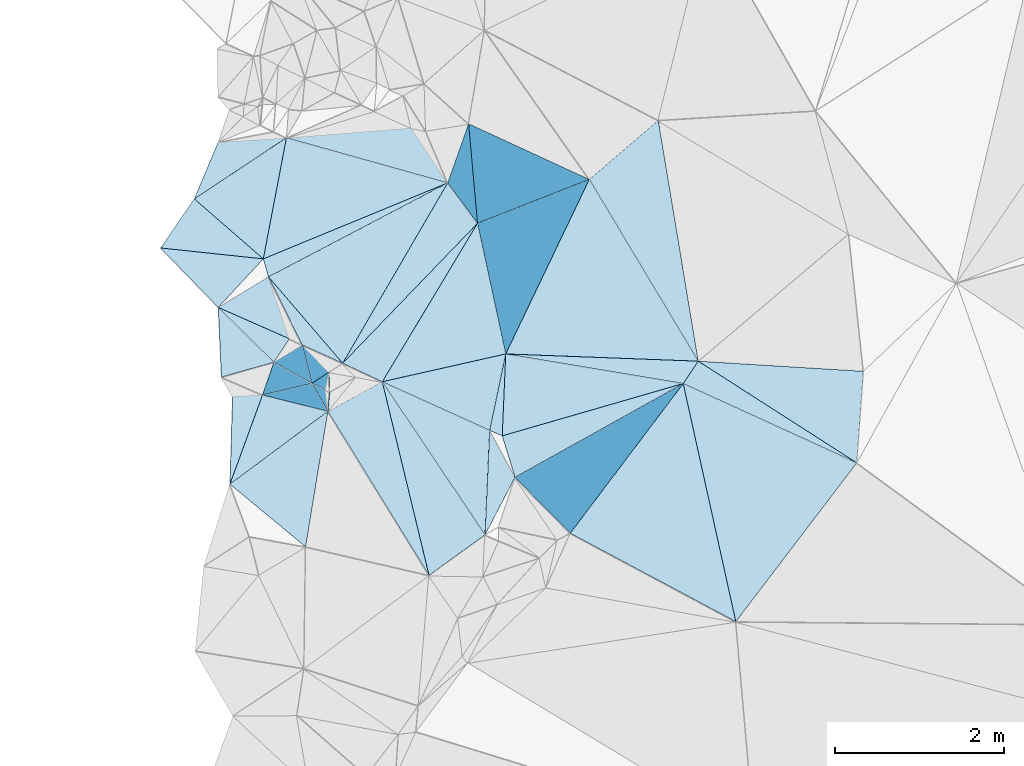
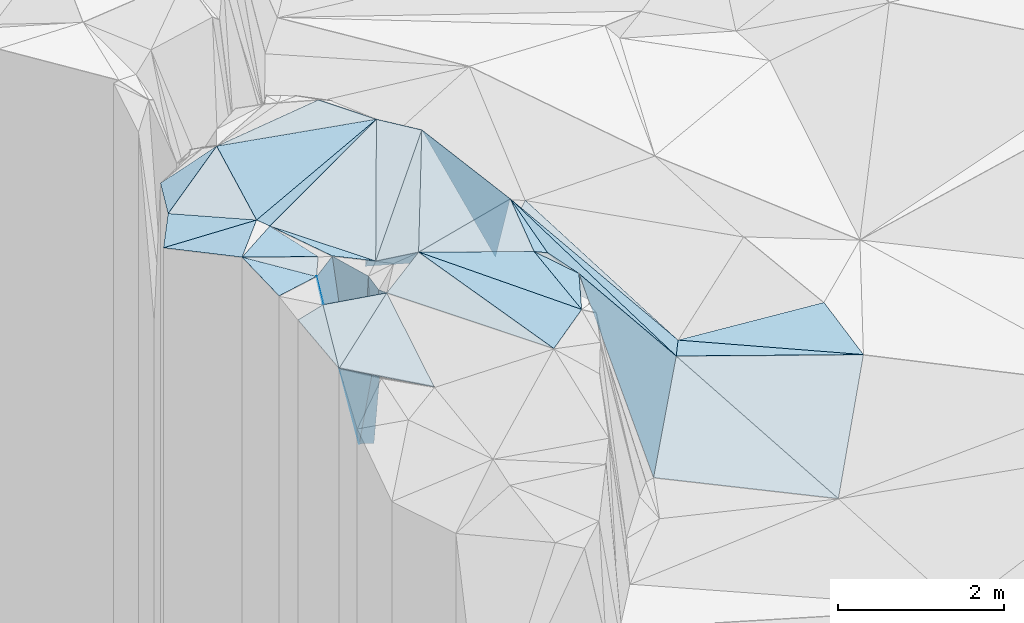
# One storey, part 72 of 275: 45 plates.
"""IFC2X3 building model written with IfcOpenShell, lengths in millimetres."""

from ifc_helpers import new_model, si_unit, frame, origin_with_axes, place, context, subcontext, project, spatial, polyline, outline, extrude, material, type_object, element, save


model = new_model("IFC2X3")

# Units and contexts
model_context = context("Model", 3, precision=1e-05, world=origin_with_axes())
body_context = subcontext(model_context, "Body", "Model", "MODEL_VIEW")
ifc_project = project(units=[si_unit("LENGTHUNIT", "METRE", prefix="MILLI"), si_unit("AREAUNIT", "SQUARE_METRE"), si_unit("VOLUMEUNIT", "CUBIC_METRE"), si_unit("MASSUNIT", "GRAM", prefix="KILO"), si_unit("TIMEUNIT", "SECOND"), si_unit("PLANEANGLEUNIT", "RADIAN"), si_unit("SOLIDANGLEUNIT", "STERADIAN"), si_unit("THERMODYNAMICTEMPERATUREUNIT", "DEGREE_CELSIUS"), si_unit("LUMINOUSINTENSITYUNIT", "LUMEN")], contexts=[model_context])

# Site, building, storey
site_placement = place(None, origin_with_axes())
site = spatial("IfcSite", under=ifc_project, at=site_placement, CompositionType="ELEMENT")
building_placement = place(site_placement, origin_with_axes())
building = spatial("IfcBuilding", under=site, at=building_placement, Name="Undefined", CompositionType="ELEMENT")
storey_placement = place(building_placement, origin_with_axes())
storey = spatial("IfcBuildingStorey", under=building, at=storey_placement, Name="Undefined", CompositionType="ELEMENT", Elevation=0.0)

# Plates
ifc_material = material()
plate_type_1 = type_object("IfcPlateType", PredefinedType="NOTDEFINED")
plate_1_placement = place(storey_placement, frame((-133019.214456108, 91804.0141480025, 54299.5073777721), z_axis=(0.0102797063063867, 0.170975746652722, -0.985221610448532), x_axis=(0.161525662162065, -0.972618108698665, -0.167103186967032)))
element("IfcPlate", 1, at=plate_1_placement, inside=storey, type_object=plate_type_1, material=ifc_material, Name="00", context=body_context, shape_type="SweptSolid", body=[
    extrude(outline(polyline([(0.0, 0.0), (2932.31982421875, 6.47560227662325e-09), (570.640319824219, 921.015502929688), (0.0, 0.0)])), frame((-8.85201319254618e-08, 2.18876761149539e-07, -0.5000001331573), z_axis=(0.0, 0.0, 1.0), x_axis=(1.0, 0.0, 0.0)), (0.0, 0.0, 1.0), 1.0),
])
plate_type_2 = type_object("IfcPlateType", PredefinedType="NOTDEFINED")
plate_2_placement = place(storey_placement, frame((-135512.316042454, 91062.5797967738, 56809.5019135538), z_axis=(0.0469086882632694, 0.0744422740113559, -0.99612143978806), x_axis=(-0.922200361025623, -0.379983834294924, -0.0718246461790003)))
element("IfcPlate", 2, at=plate_2_placement, inside=storey, type_object=plate_type_2, material=ifc_material, Name="00", context=body_context, shape_type="SweptSolid", body=[
    extrude(outline(polyline([(0.0, 0.0), (2366.87548828125, 2.14495230466127e-08), (1561.08752441406, 1222.29528808594), (0.0, 0.0)])), frame((-8.85201319254618e-08, 2.18876761149539e-07, -0.5000001331573), z_axis=(0.0, 0.0, 1.0), x_axis=(1.0, 0.0, 0.0)), (0.0, 0.0, 1.0), 1.0),
])
plate_type_3 = type_object("IfcPlateType", PredefinedType="NOTDEFINED")
plate_3_placement = place(storey_placement, frame((-135069.725982728, 86895.7332848351, 56389.5014990428), z_axis=(-0.0406248918595986, 0.066225253315251, -0.996977348782171), x_axis=(-0.555674663331847, 0.827767819080806, 0.0776279989774612)))
element("IfcPlate", 3, at=plate_3_placement, inside=storey, type_object=plate_type_3, material=ifc_material, Name="00", context=body_context, shape_type="SweptSolid", body=[
    extrude(outline(polyline([(0.0, 0.0), (2189.93139648438, 6.11908035352826e-09), (1000.53356933594, 734.801025390625), (0.0, 0.0)])), frame((-8.85201319254618e-08, 2.18876761149539e-07, -0.5000001331573), z_axis=(0.0, 0.0, 1.0), x_axis=(1.0, 0.0, 0.0)), (0.0, 0.0, 1.0), 1.0),
])
plate_type_4 = type_object("IfcPlateType", PredefinedType="NOTDEFINED")
plate_4_placement = place(storey_placement, frame((-138090.200132588, 87495.7062504348, 56219.509534676), z_axis=(0.00755487445740724, 0.194475120494153, -0.980878357076308), x_axis=(0.796288406474138, 0.592167739934259, 0.123540040051918)))
element("IfcPlate", 4, at=plate_4_placement, inside=storey, type_object=plate_type_4, material=ifc_material, Name="00", context=body_context, shape_type="SweptSolid", body=[
    extrude(outline(polyline([(0.0, 0.0), (1457.01745605469, 1.74331944435835e-08), (257.512359619141, 1142.49169921875), (0.0, 0.0)])), frame((-8.85201319254618e-08, 2.18876761149539e-07, -0.5000001331573), z_axis=(0.0, 0.0, 1.0), x_axis=(1.0, 0.0, 0.0)), (0.0, 0.0, 1.0), 1.0),
])
plate_type_5 = type_object("IfcPlateType", PredefinedType="NOTDEFINED")
plate_5_placement = place(storey_placement, frame((-136755.149502886, 88927.6789404516, 56459.5113759469), z_axis=(0.212194338874322, 0.00788030484290911, -0.977195713941313), x_axis=(0.685469337821501, 0.711502170225779, 0.154584762090448)))
element("IfcPlate", 5, at=plate_5_placement, inside=storey, type_object=plate_type_5, material=ifc_material, Name="00", context=body_context, shape_type="SweptSolid", body=[
    extrude(outline(polyline([(0.0, 0.0), (2328.8193359375, 1.71712599694729e-09), (180.7353515625, 495.009826660156), (0.0, 0.0)])), frame((-8.85201319254618e-08, 2.18876761149539e-07, -0.5000001331573), z_axis=(0.0, 0.0, 1.0), x_axis=(1.0, 0.0, 0.0)), (0.0, 0.0, 1.0), 1.0),
])
plate_type_6 = type_object("IfcPlateType", PredefinedType="NOTDEFINED")
plate_6_placement = place(storey_placement, frame((-137704.779445625, 88552.0196967348, 56379.8982663282), z_axis=(-0.901601279238394, 0.381755940301461, -0.20341468806416), x_axis=(0.3131194597647, 0.900418097282821, 0.301999096028856)))
element("IfcPlate", 6, at=plate_6_placement, inside=storey, type_object=plate_type_6, material=ifc_material, Name="00", context=body_context, shape_type="SweptSolid", body=[
    extrude(outline(polyline([(0.0, 0.0), (430.464874267578, -2.73576006293297e-09), (-396.548034667969, 2373.15185546875), (0.0, 0.0)])), frame((-8.85201319254618e-08, 2.18876761149539e-07, -0.5000001331573), z_axis=(0.0, 0.0, 1.0), x_axis=(1.0, 0.0, 0.0)), (0.0, 0.0, 1.0), 1.0),
])
plate_type_7 = type_object("IfcPlateType", PredefinedType="NOTDEFINED")
plate_7_placement = place(storey_placement, frame((-134866.757399001, 88068.1037368284, 56439.6993643037), z_axis=(-0.784587779004324, 0.151405444524645, -0.601247377046551), x_axis=(0.041968492757815, 0.98047070605122, 0.192134953069608)))
element("IfcPlate", 7, at=plate_7_placement, inside=storey, type_object=plate_type_7, material=ifc_material, Name="00", context=body_context, shape_type="SweptSolid", body=[
    extrude(outline(polyline([(0.0, 0.0), (988.888244628906, 4.97675500810146e-09), (189.809112548828, 3450.74951171875), (0.0, 0.0)])), frame((-8.85201319254618e-08, 2.18876761149539e-07, -0.5000001331573), z_axis=(0.0, 0.0, 1.0), x_axis=(1.0, 0.0, 0.0)), (0.0, 0.0, 1.0), 1.0),
])
plate_type_8 = type_object("IfcPlateType", PredefinedType="NOTDEFINED")
plate_8_placement = place(storey_placement, frame((-137695.049149037, 90163.160322179, 56639.5006148275), z_axis=(0.0476237462637835, -0.0155279606071227, -0.998744642654561), x_axis=(-0.993200359379494, 0.105602677850897, -0.0490012301801052)))
element("IfcPlate", 8, at=plate_8_placement, inside=storey, type_object=plate_type_8, material=ifc_material, Name="00", context=body_context, shape_type="SweptSolid", body=[
    extrude(outline(polyline([(0.0, 0.0), (1224.45910644531, -9.31322574615479e-10), (888.88232421875, 619.990539550781), (0.0, 0.0)])), frame((-8.85201319254618e-08, 2.18876761149539e-07, -0.5000001331573), z_axis=(0.0, 0.0, 1.0), x_axis=(1.0, 0.0, 0.0)), (0.0, 0.0, 1.0), 1.0),
])
plate_type_9 = type_object("IfcPlateType", PredefinedType="NOTDEFINED")
plate_9_placement = place(storey_placement, frame((-138090.082118024, 87495.637834506, 56219.5158988246), z_axis=(0.243513532106445, 0.0576990744786412, -0.968179723236007), x_axis=(0.0301483547749208, 0.997296237000708, 0.0670171050448606)))
element("IfcPlate", 9, at=plate_9_placement, inside=storey, type_object=plate_type_9, material=ifc_material, Name="00", context=body_context, shape_type="SweptSolid", body=[
    extrude(outline(polyline([(0.0, 0.0), (1044.50939941406, -3.79804987460375e-09), (1075.72033691406, 364.590026855469), (0.0, 0.0)])), frame((-8.85201319254618e-08, 2.18876761149539e-07, -0.5000001331573), z_axis=(0.0, 0.0, 1.0), x_axis=(1.0, 0.0, 0.0)), (0.0, 0.0, 1.0), 1.0),
])
plate_type_10 = type_object("IfcPlateType", PredefinedType="NOTDEFINED")
plate_10_placement = place(storey_placement, frame((-136755.368464417, 88927.6732586223, 56459.5129054558), z_axis=(-0.225812033892531, -0.00342194722023315, -0.97416488112975), x_axis=(-0.892356136575741, 0.401865812004755, 0.205437081991972)))
element("IfcPlate", 10, at=plate_10_placement, inside=storey, type_object=plate_type_10, material=ifc_material, Name="00", context=body_context, shape_type="SweptSolid", body=[
    extrude(outline(polyline([(0.0, 0.0), (535.443725585938, -4.27826307713985e-09), (1235.61071777344, 573.991516113281), (0.0, 0.0)])), frame((-8.85201319254618e-08, 2.18876761149539e-07, -0.5000001331573), z_axis=(0.0, 0.0, 1.0), x_axis=(1.0, 0.0, 0.0)), (0.0, 0.0, 1.0), 1.0),
])
plate_type_11 = type_object("IfcPlateType", PredefinedType="NOTDEFINED")
plate_11_placement = place(storey_placement, frame((-138228.253617538, 89588.5701485262, 56629.5034068954), z_axis=(-0.0199411727914742, 0.115282046232752, -0.993132619262951), x_axis=(0.853834207138096, 0.518759924394001, 0.0430730491559356)))
element("IfcPlate", 11, at=plate_11_placement, inside=storey, type_object=plate_type_11, material=ifc_material, Name="00", context=body_context, shape_type="SweptSolid", body=[
    extrude(outline(polyline([(0.0, 0.0), (696.4912109375, 4.13274392485619e-09), (523.768249511719, 758.990661621094), (0.0, 0.0)])), frame((-8.85201319254618e-08, 2.18876761149539e-07, -0.5000001331573), z_axis=(0.0, 0.0, 1.0), x_axis=(1.0, 0.0, 0.0)), (0.0, 0.0, 1.0), 1.0),
])
plate_type_12 = type_object("IfcPlateType", PredefinedType="NOTDEFINED")
plate_12_placement = place(storey_placement, frame((-132545.912939233, 88952.1395896651, 53809.7193433031), z_axis=(-0.676516597305727, 0.476739187252369, -0.561288732211712), x_axis=(-0.55825685568079, -0.829076551856979, -0.031326574123883)))
element("IfcPlate", 12, at=plate_12_placement, inside=storey, type_object=plate_type_12, material=ifc_material, Name="00", context=body_context, shape_type="SweptSolid", body=[
    extrude(outline(polyline([(0.0, 0.0), (319.217803955078, 2.61934474110603e-09), (1113.033203125, 3451.96435546875), (0.0, 0.0)])), frame((-8.85201319254618e-08, 2.18876761149539e-07, -0.5000001331573), z_axis=(0.0, 0.0, 1.0), x_axis=(1.0, 0.0, 0.0)), (0.0, 0.0, 1.0), 1.0),
])
plate_type_13 = type_object("IfcPlateType", PredefinedType="NOTDEFINED")
plate_13_placement = place(storey_placement, frame((-134715.401101913, 87577.2415554032, 56379.6779337774), z_axis=(-0.749592922415684, -0.152423767629284, -0.644109808748484), x_axis=(-0.292718936251035, 0.949129923037372, 0.116051771012485)))
element("IfcPlate", 13, at=plate_13_placement, inside=storey, type_object=plate_type_13, material=ifc_material, Name="00", context=body_context, shape_type="SweptSolid", body=[
    extrude(outline(polyline([(0.0, 0.0), (517.010620117188, 7.42147676646709e-10), (171.176361083984, 3438.61865234375), (0.0, 0.0)])), frame((-8.85201319254618e-08, 2.18876761149539e-07, -0.5000001331573), z_axis=(0.0, 0.0, 1.0), x_axis=(1.0, 0.0, 0.0)), (0.0, 0.0, 1.0), 1.0),
])
plate_type_14 = type_object("IfcPlateType", PredefinedType="NOTDEFINED")
plate_14_placement = place(storey_placement, frame((-137120.43305099, 88689.3291927236, 54049.9519806931), z_axis=(-0.400933713068421, -0.91106170820296, -0.0960141738050935), x_axis=(0.916010796100385, -0.397164333799256, -0.0564332648828032)))
element("IfcPlate", 14, at=plate_14_placement, inside=storey, type_object=plate_type_14, material=ifc_material, Name="00", context=body_context, shape_type="SweptSolid", body=[
    extrude(outline(polyline([(0.0, 0.0), (177.200454711914, 2.09547579288483e-09), (173.250122070313, 2374.54931640625), (0.0, 0.0)])), frame((-8.85201319254618e-08, 2.18876761149539e-07, -0.5000001331573), z_axis=(0.0, 0.0, 1.0), x_axis=(1.0, 0.0, 0.0)), (0.0, 0.0, 1.0), 1.0),
])
plate_15_placement = place(storey_placement, frame((-136916.704785946, 88823.8694605502, 56359.956241492), z_axis=(0.391733126977046, 0.915912209491296, -0.0874641740003226), x_axis=(-0.0176079577659123, -0.0875813731552263, -0.996001738401876)))
element("IfcPlate", 15, at=plate_15_placement, inside=storey, type_object=plate_type_14, material=ifc_material, Name="00", context=body_context, shape_type="SweptSolid", body=[
    extrude(outline(polyline([(0.0, 0.0), (2329.31323242188, -5.96628524363041e-09), (2316.04760742188, 176.703201293945), (0.0, 0.0)])), frame((-8.85201319254618e-08, 2.18876761149539e-07, -0.5000001331573), z_axis=(0.0, 0.0, 1.0), x_axis=(1.0, 0.0, 0.0)), (0.0, 0.0, 1.0), 1.0),
])
plate_type_15 = type_object("IfcPlateType", PredefinedType="NOTDEFINED")
plate_16_placement = place(storey_placement, frame((-130668.546409526, 87748.1052065247, 53669.5012166673), z_axis=(-0.0350781551410021, 0.0613103172055421, -0.997502164426754), x_axis=(-0.908035396471917, 0.414937188493061, 0.0574356018473136)))
element("IfcPlate", 16, at=plate_16_placement, inside=storey, type_object=plate_type_15, material=ifc_material, Name="00", context=body_context, shape_type="SweptSolid", body=[
    extrude(outline(polyline([(0.0, 0.0), (2263.40454101563, 8.83301254361868e-09), (2211.9775390625, 315.048034667969), (0.0, 0.0)])), frame((-8.85201319254618e-08, 2.18876761149539e-07, -0.5000001331573), z_axis=(0.0, 0.0, 1.0), x_axis=(1.0, 0.0, 0.0)), (0.0, 0.0, 1.0), 1.0),
])
plate_type_16 = type_object("IfcPlateType", PredefinedType="NOTDEFINED")
plate_17_placement = place(storey_placement, frame((-136755.266391725, 88927.7619792935, 56459.5077355599), z_axis=(-0.0216654402157595, 0.174017716652183, -0.984504160982277), x_axis=(-0.644659688367644, 0.750242950066391, 0.146797145985239)))
element("IfcPlate", 17, at=plate_17_placement, inside=storey, type_object=plate_type_16, material=ifc_material, Name="00", context=body_context, shape_type="SweptSolid", body=[
    extrude(outline(polyline([(0.0, 0.0), (1362.42431640625, -1.91503204405308e-08), (851.790466308594, 2345.09130859375), (0.0, 0.0)])), frame((-8.85201319254618e-08, 2.18876761149539e-07, -0.5000001331573), z_axis=(0.0, 0.0, 1.0), x_axis=(1.0, 0.0, 0.0)), (0.0, 0.0, 1.0), 1.0),
])
plate_type_17 = type_object("IfcPlateType", PredefinedType="NOTDEFINED")
plate_18_placement = place(storey_placement, frame((-137704.29972498, 88551.893222071, 56379.5049994247), z_axis=(0.0577590349431024, 0.128864102756606, -0.989978755783768), x_axis=(0.969885675995921, -0.242268912774627, 0.0250509361289355)))
element("IfcPlate", 18, at=plate_18_placement, inside=storey, type_object=plate_type_17, material=ifc_material, Name="00", context=body_context, shape_type="SweptSolid", body=[
    extrude(outline(polyline([(0.0, 0.0), (798.373352050781, 5.18775777891278e-09), (-122.373825073242, 1129.21411132813), (0.0, 0.0)])), frame((-8.85201319254618e-08, 2.18876761149539e-07, -0.5000001331573), z_axis=(0.0, 0.0, 1.0), x_axis=(1.0, 0.0, 0.0)), (0.0, 0.0, 1.0), 1.0),
])
plate_type_18 = type_object("IfcPlateType", PredefinedType="NOTDEFINED")
plate_19_placement = place(storey_placement, frame((-137233.3052034, 89143.2795383306, 56569.9121385493), z_axis=(-0.486191840763157, 0.856012644357831, -0.175669709041847), x_axis=(0.0440243342604755, -0.17677971304545, -0.98326537163092)))
element("IfcPlate", 19, at=plate_19_placement, inside=storey, type_object=plate_type_18, material=ifc_material, Name="00", context=body_context, shape_type="SweptSolid", body=[
    extrude(outline(polyline([(0.0, 0.0), (2562.88891601563, -1.60071067512035e-10), (80.143928527832, 389.585601806641), (0.0, 0.0)])), frame((-8.85201319254618e-08, 2.18876761149539e-07, -0.5000001331573), z_axis=(0.0, 0.0, 1.0), x_axis=(1.0, 0.0, 0.0)), (0.0, 0.0, 1.0), 1.0),
])
plate_type_19 = type_object("IfcPlateType", PredefinedType="NOTDEFINED")
plate_20_placement = place(storey_placement, frame((-133836.286220271, 91103.7548794404, 54169.7079565292), z_axis=(-0.73552958499505, -0.343315165919083, -0.584064145832427), x_axis=(0.509028183156125, -0.848953245880516, -0.142016530945204)))
element("IfcPlate", 20, at=plate_20_placement, inside=storey, type_object=plate_type_19, material=ifc_material, Name="00", context=body_context, shape_type="SweptSolid", body=[
    extrude(outline(polyline([(0.0, 0.0), (2534.91625976563, -8.99308361113071e-09), (901.449951171875, 3238.31567382813), (0.0, 0.0)])), frame((-8.85201319254618e-08, 2.18876761149539e-07, -0.5000001331573), z_axis=(0.0, 0.0, 1.0), x_axis=(1.0, 0.0, 0.0)), (0.0, 0.0, 1.0), 1.0),
])
plate_type_20 = type_object("IfcPlateType", PredefinedType="NOTDEFINED")
plate_21_placement = place(storey_placement, frame((-135512.270422481, 91062.5832657927, 56809.506453365), z_axis=(0.138062531238084, 0.0814448888878982, -0.987069130072545), x_axis=(0.594505200440239, -0.803915792332117, 0.0168215780631777)))
element("IfcPlate", 21, at=plate_21_placement, inside=storey, type_object=plate_type_20, material=ifc_material, Name="00", context=body_context, shape_type="SweptSolid", body=[
    extrude(outline(polyline([(0.0, 0.0), (594.474548339844, 1.81898940354586e-09), (971.446105957031, 2298.10620117188), (0.0, 0.0)])), frame((-8.85201319254618e-08, 2.18876761149539e-07, -0.5000001331573), z_axis=(0.0, 0.0, 1.0), x_axis=(1.0, 0.0, 0.0)), (0.0, 0.0, 1.0), 1.0),
])
plate_type_21 = type_object("IfcPlateType", PredefinedType="NOTDEFINED")
plate_22_placement = place(storey_placement, frame((-130590.261974152, 88832.3503455849, 53749.5015822328), z_axis=(-0.0259746258578682, 0.0754247048161328, -0.996813138313768), x_axis=(-0.0718163298118543, -0.994713859794599, -0.0733944950584577)))
element("IfcPlate", 22, at=plate_22_placement, inside=storey, type_object=plate_type_21, material=ifc_material, Name="00", context=body_context, shape_type="SweptSolid", body=[
    extrude(outline(polyline([(0.0, 0.0), (1090.0, -5.2677933126688e-09), (17.0642204284668, 1959.82360839844), (0.0, 0.0)])), frame((-8.85201319254618e-08, 2.18876761149539e-07, -0.5000001331573), z_axis=(0.0, 0.0, 1.0), x_axis=(1.0, 0.0, 0.0)), (0.0, 0.0, 1.0), 1.0),
])
plate_type_22 = type_object("IfcPlateType", PredefinedType="NOTDEFINED")
plate_23_placement = place(storey_placement, frame((-137421.104368638, 91596.3324875106, 56759.5041886007), z_axis=(0.113941999720962, 0.0612515422511678, -0.991597433070216), x_axis=(-0.187097931852085, -0.978915600208797, -0.0819671371009327)))
element("IfcPlate", 23, at=plate_23_placement, inside=storey, type_object=plate_type_22, material=ifc_material, Name="00", context=body_context, shape_type="SweptSolid", body=[
    extrude(outline(polyline([(0.0, 0.0), (1464.00134277344, 5.55883161723614e-09), (925.613891601563, 940.552429199219), (0.0, 0.0)])), frame((-8.85201319254618e-08, 2.18876761149539e-07, -0.5000001331573), z_axis=(0.0, 0.0, 1.0), x_axis=(1.0, 0.0, 0.0)), (0.0, 0.0, 1.0), 1.0),
])
plate_type_23 = type_object("IfcPlateType", PredefinedType="NOTDEFINED")
plate_24_placement = place(storey_placement, frame((-137421.021412278, 91596.2010605932, 56759.5306690156), z_axis=(0.279853679932957, -0.201601117665587, -0.938636728017804), x_axis=(-0.82666728889391, -0.547745699147896, -0.128824852174477)))
element("IfcPlate", 24, at=plate_24_placement, inside=storey, type_object=plate_type_23, material=ifc_material, Name="00", context=body_context, shape_type="SweptSolid", body=[
    extrude(outline(polyline([(0.0, 0.0), (1319.62121582031, -3.82715370506048e-09), (725.89013671875, 426.59521484375), (0.0, 0.0)])), frame((-8.85201319254618e-08, 2.18876761149539e-07, -0.5000001331573), z_axis=(0.0, 0.0, 1.0), x_axis=(1.0, 0.0, 0.0)), (0.0, 0.0, 1.0), 1.0),
])
plate_type_24 = type_object("IfcPlateType", PredefinedType="NOTDEFINED")
plate_25_placement = place(storey_placement, frame((-130668.510324455, 87748.1824509821, 53669.5121235469), z_axis=(0.0369168066107426, 0.215847948346143, -0.975728862227835), x_axis=(-0.594447365061265, -0.780116369419031, -0.195066092225658)))
element("IfcPlate", 25, at=plate_25_placement, inside=storey, type_object=plate_type_24, material=ifc_material, Name="00", context=body_context, shape_type="SweptSolid", body=[
    extrude(outline(polyline([(0.0, 0.0), (2409.43969726563, -4.30736690759659e-09), (463.717742919922, 2215.39282226563), (0.0, 0.0)])), frame((-8.85201319254618e-08, 2.18876761149539e-07, -0.5000001331573), z_axis=(0.0, 0.0, 1.0), x_axis=(1.0, 0.0, 0.0)), (0.0, 0.0, 1.0), 1.0),
])
plate_type_25 = type_object("IfcPlateType", PredefinedType="NOTDEFINED")
plate_26_placement = place(storey_placement, frame((-132724.14902056, 88687.5447196354, 53799.8441710309), z_axis=(-0.737643403191221, 0.598971354874783, -0.311633640302104), x_axis=(-0.598957005947847, -0.793537563261105, -0.107464602170286)))
element("IfcPlate", 26, at=plate_26_placement, inside=storey, type_object=plate_type_25, material=ifc_material, Name="00", context=body_context, shape_type="SweptSolid", body=[
    extrude(outline(polyline([(0.0, 0.0), (2233.29345703125, 3.98722477257252e-09), (1796.18127441406, 2937.1982421875), (0.0, 0.0)])), frame((-8.85201319254618e-08, 2.18876761149539e-07, -0.5000001331573), z_axis=(0.0, 0.0, 1.0), x_axis=(1.0, 0.0, 0.0)), (0.0, 0.0, 1.0), 1.0),
])
plate_type_26 = type_object("IfcPlateType", PredefinedType="NOTDEFINED")
plate_27_placement = place(storey_placement, frame((-137421.134907738, 91596.3498147393, 56759.5029938752), z_axis=(0.0528543484694343, 0.0959050706900059, -0.993986234946851), x_axis=(0.995004741802528, 0.0793562711845507, 0.0605652211600686)))
element("IfcPlate", 27, at=plate_27_placement, inside=storey, type_object=plate_type_26, material=ifc_material, Name="00", context=body_context, shape_type="SweptSolid", body=[
    extrude(outline(polyline([(0.0, 0.0), (1486.00134277344, -1.75496097654104e-08), (1859.95788574219, 686.69970703125), (0.0, 0.0)])), frame((-8.85201319254618e-08, 2.18876761149539e-07, -0.5000001331573), z_axis=(0.0, 0.0, 1.0), x_axis=(1.0, 0.0, 0.0)), (0.0, 0.0, 1.0), 1.0),
])
plate_type_27 = type_object("IfcPlateType", PredefinedType="NOTDEFINED")
plate_28_placement = place(storey_placement, frame((-135015.548308653, 88133.4009363391, 56469.5127692486), z_axis=(-0.110376765991792, 0.195677184783532, -0.974436970195807), x_axis=(0.20324709073217, 0.964152368860748, 0.170589653054097)))
element("IfcPlate", 28, at=plate_28_placement, inside=storey, type_object=plate_type_27, material=ifc_material, Name="00", context=body_context, shape_type="SweptSolid", body=[
    extrude(outline(polyline([(0.0, 0.0), (937.923217773438, 4.36557456851006e-09), (-37.7429618835449, 161.169067382813), (0.0, 0.0)])), frame((-8.85201319254618e-08, 2.18876761149539e-07, -0.5000001331573), z_axis=(0.0, 0.0, 1.0), x_axis=(1.0, 0.0, 0.0)), (0.0, 0.0, 1.0), 1.0),
])
plate_type_28 = type_object("IfcPlateType", PredefinedType="NOTDEFINED")
plate_29_placement = place(storey_placement, frame((-136286.590959578, 88708.5412595688, 56559.5075018352), z_axis=(0.00832130601585026, 0.172518984968256, -0.984971043072695), x_axis=(0.97450976773399, 0.219437549157256, 0.0466677041528911)))
element("IfcPlate", 29, at=plate_29_placement, inside=storey, type_object=plate_type_28, material=ifc_material, Name="00", context=body_context, shape_type="SweptSolid", body=[
    extrude(outline(polyline([(0.0, 0.0), (1499.96667480469, -1.86118995770812e-08), (1108.29125976563, 852.226745605469), (0.0, 0.0)])), frame((-8.85201319254618e-08, 2.18876761149539e-07, -0.5000001331573), z_axis=(0.0, 0.0, 1.0), x_axis=(1.0, 0.0, 0.0)), (0.0, 0.0, 1.0), 1.0),
])
plate_type_29 = type_object("IfcPlateType", PredefinedType="NOTDEFINED")
plate_30_placement = place(storey_placement, frame((-135015.575003079, 88133.3384869109, 56469.5080088523), z_axis=(-0.163761487657682, 0.0707775812320557, -0.983957676505998), x_axis=(0.470687558237028, -0.870962640939366, -0.140986880981139)))
element("IfcPlate", 30, at=plate_30_placement, inside=storey, type_object=plate_type_29, material=ifc_material, Name="00", context=body_context, shape_type="SweptSolid", body=[
    extrude(outline(polyline([(0.0, 0.0), (638.357238769531, -3.33238858729601e-09), (1063.66772460938, 640.008605957031), (0.0, 0.0)])), frame((-8.85201319254618e-08, 2.18876761149539e-07, -0.5000001331573), z_axis=(0.0, 0.0, 1.0), x_axis=(1.0, 0.0, 0.0)), (0.0, 0.0, 1.0), 1.0),
])
plate_type_30 = type_object("IfcPlateType", PredefinedType="NOTDEFINED")
plate_31_placement = place(storey_placement, frame((-137386.224432819, 89217.3724263151, 56569.5101305174), z_axis=(0.0181787627603177, 0.199573292301133, -0.979714261192819), x_axis=(-0.541961928985243, -0.821467428400332, -0.177393719189662)))
element("IfcPlate", 31, at=plate_31_placement, inside=storey, type_object=plate_type_30, material=ifc_material, Name="00", context=body_context, shape_type="SweptSolid", body=[
    extrude(outline(polyline([(0.0, 0.0), (338.230682373047, -1.74622982740402e-09), (140.732345581055, 911.369506835938), (0.0, 0.0)])), frame((-8.85201319254618e-08, 2.18876761149539e-07, -0.5000001331573), z_axis=(0.0, 0.0, 1.0), x_axis=(1.0, 0.0, 0.0)), (0.0, 0.0, 1.0), 1.0),
])
plate_type_31 = type_object("IfcPlateType", PredefinedType="NOTDEFINED")
plate_32_placement = place(storey_placement, frame((-136957.417503971, 88619.3589092255, 54039.9887810954), z_axis=(0.995106621433407, -0.0962311072361339, -0.0224139684013892), x_axis=(0.0210794428478934, -0.0148623330360006, 0.999667328737891)))
element("IfcPlate", 32, at=plate_32_placement, inside=storey, type_object=plate_type_31, material=ifc_material, Name="00", context=body_context, shape_type="SweptSolid", body=[
    extrude(outline(polyline([(0.0, 0.0), (2260.75219726563, -5.16592990607023e-09), (2363.68237304688, 226.947891235352), (0.0, 0.0)])), frame((-8.85201319254618e-08, 2.18876761149539e-07, -0.5000001331573), z_axis=(0.0, 0.0, 1.0), x_axis=(1.0, 0.0, 0.0)), (0.0, 0.0, 1.0), 1.0),
])
plate_type_32 = type_object("IfcPlateType", PredefinedType="NOTDEFINED")
plate_33_placement = place(storey_placement, frame((-136916.400991721, 88823.4280349562, 56359.9896992997), z_axis=(0.999239362739237, 0.0331246756518717, -0.0205779448789557), x_axis=(0.0270889862571029, -0.969208966293327, -0.244745105119967)))
element("IfcPlate", 33, at=plate_33_placement, inside=storey, type_object=plate_type_32, material=ifc_material, Name="00", context=body_context, shape_type="SweptSolid", body=[
    extrude(outline(polyline([(0.0, 0.0), (245.153015136719, -1.16415321826935e-09), (764.420532226563, 2200.30932617188), (0.0, 0.0)])), frame((-8.85201319254618e-08, 2.18876761149539e-07, -0.5000001331573), z_axis=(0.0, 0.0, 1.0), x_axis=(1.0, 0.0, 0.0)), (0.0, 0.0, 1.0), 1.0),
])
plate_type_33 = type_object("IfcPlateType", PredefinedType="NOTDEFINED")
plate_34_placement = place(storey_placement, frame((-136930.116658379, 88357.9256150815, 56399.9416290572), z_axis=(-0.23784989052668, -0.964263618387424, -0.116718052720381), x_axis=(-0.969885675970524, 0.242268912773047, -0.0250509371274838)))
element("IfcPlate", 34, at=plate_34_placement, inside=storey, type_object=plate_type_33, material=ifc_material, Name="00", context=body_context, shape_type="SweptSolid", body=[
    extrude(outline(polyline([(0.0, 0.0), (798.373352050781, 5.18775777891278e-09), (323.658111572266, 2358.75927734375), (0.0, 0.0)])), frame((-8.85201319254618e-08, 2.18876761149539e-07, -0.5000001331573), z_axis=(0.0, 0.0, 1.0), x_axis=(1.0, 0.0, 0.0)), (0.0, 0.0, 1.0), 1.0),
])
plate_type_34 = type_object("IfcPlateType", PredefinedType="NOTDEFINED")
plate_35_placement = place(storey_placement, frame((-132100.852732479, 85868.5266808875, 53199.5107436366), z_axis=(-0.0776445941744424, 0.191117557402601, -0.978491387927328), x_axis=(-0.870824732047607, 0.464862466762777, 0.159897382872391)))
element("IfcPlate", 35, at=plate_35_placement, inside=storey, type_object=plate_type_34, material=ifc_material, Name="00", context=body_context, shape_type="SweptSolid", body=[
    extrude(outline(polyline([(0.0, 0.0), (2251.44409179688, 2.36068444792181e-08), (1948.79382324219, 2212.69140625), (0.0, 0.0)])), frame((-8.85201319254618e-08, 2.18876761149539e-07, -0.5000001331573), z_axis=(0.0, 0.0, 1.0), x_axis=(1.0, 0.0, 0.0)), (0.0, 0.0, 1.0), 1.0),
])
plate_type_35 = type_object("IfcPlateType", PredefinedType="NOTDEFINED")
plate_36_placement = place(storey_placement, frame((-135732.568234224, 86416.8094266446, 56339.5118474967), z_axis=(0.169499894641229, 0.134691967228912, -0.976282674065569), x_axis=(-0.524702234285829, 0.850879679029675, 0.0262932909658737)))
element("IfcPlate", 36, at=plate_36_placement, inside=storey, type_object=plate_type_35, material=ifc_material, Name="00", context=body_context, shape_type="SweptSolid", body=[
    extrude(outline(polyline([(0.0, 0.0), (2281.95092773438, -1.98560883291066e-08), (2246.4111328125, 748.890441894531), (0.0, 0.0)])), frame((-8.85201319254618e-08, 2.18876761149539e-07, -0.5000001331573), z_axis=(0.0, 0.0, 1.0), x_axis=(1.0, 0.0, 0.0)), (0.0, 0.0, 1.0), 1.0),
])
plate_type_36 = type_object("IfcPlateType", PredefinedType="NOTDEFINED")
plate_37_placement = place(storey_placement, frame((-138228.288614668, 89588.5585441841, 56629.5041318658), z_axis=(-0.0899330051240767, 0.0920724675629696, -0.991682769491443), x_axis=(0.706364994087947, -0.696052553723735, -0.128683089727447)))
element("IfcPlate", 37, at=plate_37_placement, inside=storey, type_object=plate_type_36, material=ifc_material, Name="00", context=body_context, shape_type="SweptSolid", body=[
    extrude(outline(polyline([(0.0, 0.0), (932.5234375, -2.35741026699543e-09), (611.030212402344, 562.087280273438), (0.0, 0.0)])), frame((-8.85201319254618e-08, 2.18876761149539e-07, -0.5000001331573), z_axis=(0.0, 0.0, 1.0), x_axis=(1.0, 0.0, 0.0)), (0.0, 0.0, 1.0), 1.0),
])
plate_type_37 = type_object("IfcPlateType", PredefinedType="NOTDEFINED")
plate_38_placement = place(storey_placement, frame((-137232.725677876, 89143.2179095921, 56569.9491662465), z_axis=(0.672861070419609, 0.732756728236526, -0.101614748623813), x_axis=(0.637313496464415, -0.643922401088145, -0.423314833901649)))
element("IfcPlate", 38, at=plate_38_placement, inside=storey, type_object=plate_type_37, material=ifc_material, Name="00", context=body_context, shape_type="SweptSolid", body=[
    extrude(outline(polyline([(0.0, 0.0), (496.084655761719, -8.73114913702011e-11), (1430.40100097656, 2126.58251953125), (0.0, 0.0)])), frame((-8.85201319254618e-08, 2.18876761149539e-07, -0.5000001331573), z_axis=(0.0, 0.0, 1.0), x_axis=(1.0, 0.0, 0.0)), (0.0, 0.0, 1.0), 1.0),
])
plate_type_38 = type_object("IfcPlateType", PredefinedType="NOTDEFINED")
plate_39_placement = place(storey_placement, frame((-134825.301110856, 89037.5378883234, 56629.7682844886), z_axis=(-0.876228854544147, -0.132298237430541, -0.463379078980724), x_axis=(-0.209565559282023, 0.970502586963156, 0.119193141835569)))
element("IfcPlate", 39, at=plate_39_placement, inside=storey, type_object=plate_type_38, material=ifc_material, Name="00", context=body_context, shape_type="SweptSolid", body=[
    extrude(outline(polyline([(0.0, 0.0), (1594.05139160156, 5.4424162954092e-09), (1504.90747070313, 3005.75341796875), (0.0, 0.0)])), frame((-8.85201319254618e-08, 2.18876761149539e-07, -0.5000001331573), z_axis=(0.0, 0.0, 1.0), x_axis=(1.0, 0.0, 0.0)), (0.0, 0.0, 1.0), 1.0),
])
plate_type_39 = type_object("IfcPlateType", PredefinedType="NOTDEFINED")
plate_40_placement = place(storey_placement, frame((-137633.503953512, 89949.7926085656, 56659.5036585845), z_axis=(0.103370597562958, -0.0632477071102349, -0.992629964843282), x_axis=(-0.27594314513923, 0.956978103643281, -0.0897122611351372)))
element("IfcPlate", 40, at=plate_40_placement, inside=storey, type_object=plate_type_39, material=ifc_material, Name="00", context=body_context, shape_type="SweptSolid", body=[
    extrude(outline(polyline([(0.0, 0.0), (222.934967041016, -2.2846506908536e-09), (466.055206298828, 2354.35620117188), (0.0, 0.0)])), frame((-8.85201319254618e-08, 2.18876761149539e-07, -0.5000001331573), z_axis=(0.0, 0.0, 1.0), x_axis=(1.0, 0.0, 0.0)), (0.0, 0.0, 1.0), 1.0),
])
plate_type_40 = type_object("IfcPlateType", PredefinedType="NOTDEFINED")
plate_41_placement = place(storey_placement, frame((-135264.625937839, 91762.3545006623, 54139.887334199), z_axis=(-0.781101709859595, -0.582347804100572, -0.225280167599502), x_axis=(0.0359511289139739, -0.402138062083463, 0.914872939458572)))
element("IfcPlate", 41, at=plate_41_placement, inside=storey, type_object=plate_type_40, material=ifc_material, Name="00", context=body_context, shape_type="SweptSolid", body=[
    extrude(outline(polyline([(0.0, 0.0), (2929.36865234375, -2.21189111471176e-09), (2715.32934570313, 554.605407714844), (0.0, 0.0)])), frame((-8.85201319254618e-08, 2.18876761149539e-07, -0.5000001331573), z_axis=(0.0, 0.0, 1.0), x_axis=(1.0, 0.0, 0.0)), (0.0, 0.0, 1.0), 1.0),
])
plate_type_41 = type_object("IfcPlateType", PredefinedType="NOTDEFINED")
plate_42_placement = place(storey_placement, frame((-138228.220384833, 89588.4996166868, 56629.500680928), z_axis=(0.0465248121123672, -0.0257890500266688, -0.998584181106746), x_axis=(-0.695417745962481, 0.716799931644134, -0.0509118512276523)))
element("IfcPlate", 42, at=plate_42_placement, inside=storey, type_object=plate_type_41, material=ifc_material, Name="00", context=body_context, shape_type="SweptSolid", body=[
    extrude(outline(polyline([(0.0, 0.0), (982.089599609375, -6.4537744037807e-09), (40.6276588439941, 782.910827636719), (0.0, 0.0)])), frame((-8.85201319254618e-08, 2.18876761149539e-07, -0.5000001331573), z_axis=(0.0, 0.0, 1.0), x_axis=(1.0, 0.0, 0.0)), (0.0, 0.0, 1.0), 1.0),
])
plate_type_42 = type_object("IfcPlateType", PredefinedType="NOTDEFINED")
plate_43_placement = place(storey_placement, frame((-136286.592593391, 88708.503422556, 56559.5023278423), z_axis=(0.00513923496715676, 0.0967883087391871, -0.995291721836046), x_axis=(0.55567466337011, -0.827767819072884, -0.0776279987880403)))
element("IfcPlate", 43, at=plate_43_placement, inside=storey, type_object=plate_type_42, material=ifc_material, Name="00", context=body_context, shape_type="SweptSolid", body=[
    extrude(outline(polyline([(0.0, 0.0), (2189.93139648438, 6.11908035352826e-09), (2221.89599609375, 818.766296386719), (0.0, 0.0)])), frame((-8.85201319254618e-08, 2.18876761149539e-07, -0.5000001331573), z_axis=(0.0, 0.0, 1.0), x_axis=(1.0, 0.0, 0.0)), (0.0, 0.0, 1.0), 1.0),
])
plate_type_43 = type_object("IfcPlateType", PredefinedType="NOTDEFINED")
plate_44_placement = place(storey_placement, frame((-135158.91170948, 90584.6980616024, 56819.5040477673), z_axis=(0.0191376338268332, 0.125947708835043, -0.991852270053718), x_axis=(0.209565559274842, -0.97050258696396, -0.11919314184165)))
element("IfcPlate", 44, at=plate_44_placement, inside=storey, type_object=plate_type_43, material=ifc_material, Name="00", context=body_context, shape_type="SweptSolid", body=[
    extrude(outline(polyline([(0.0, 0.0), (1594.05139160156, 5.4424162954092e-09), (1615.50622558594, 1499.81323242188), (0.0, 0.0)])), frame((-8.85201319254618e-08, 2.18876761149539e-07, -0.5000001331573), z_axis=(0.0, 0.0, 1.0), x_axis=(1.0, 0.0, 0.0)), (0.0, 0.0, 1.0), 1.0),
])
plate_type_44 = type_object("IfcPlateType", PredefinedType="NOTDEFINED")
plate_45_placement = place(storey_placement, frame((-133836.110843139, 91103.5013234153, 54169.8206141636), z_axis=(-0.38469779330723, -0.850486853201028, -0.358719556696818), x_axis=(-0.439963349047951, -0.172689898954363, 0.881255042705369)))
element("IfcPlate", 45, at=plate_45_placement, inside=storey, type_object=plate_type_44, material=ifc_material, Name="00", context=body_context, shape_type="SweptSolid", body=[
    extrude(outline(polyline([(0.0, 0.0), (3007.07495117188, -1.00117176771164e-08), (488.215301513672, 1495.50854492188), (0.0, 0.0)])), frame((-8.85201319254618e-08, 2.18876761149539e-07, -0.5000001331573), z_axis=(0.0, 0.0, 1.0), x_axis=(1.0, 0.0, 0.0)), (0.0, 0.0, 1.0), 1.0),
])

save(model, "model.ifc")
